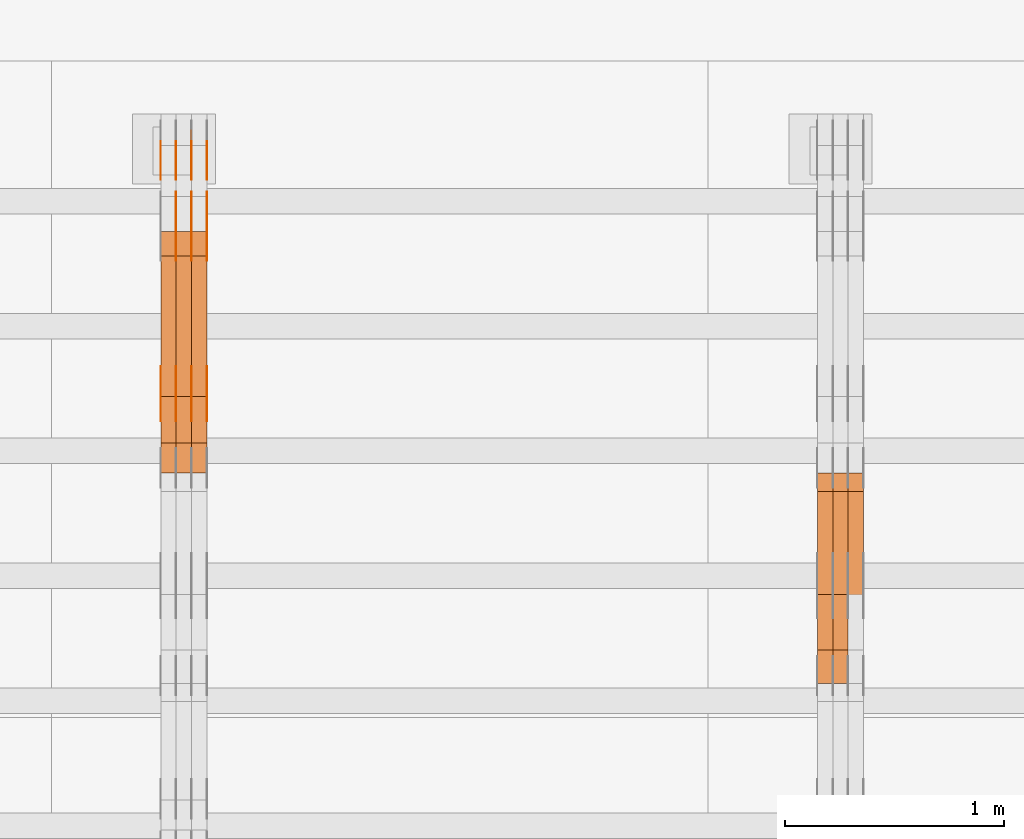
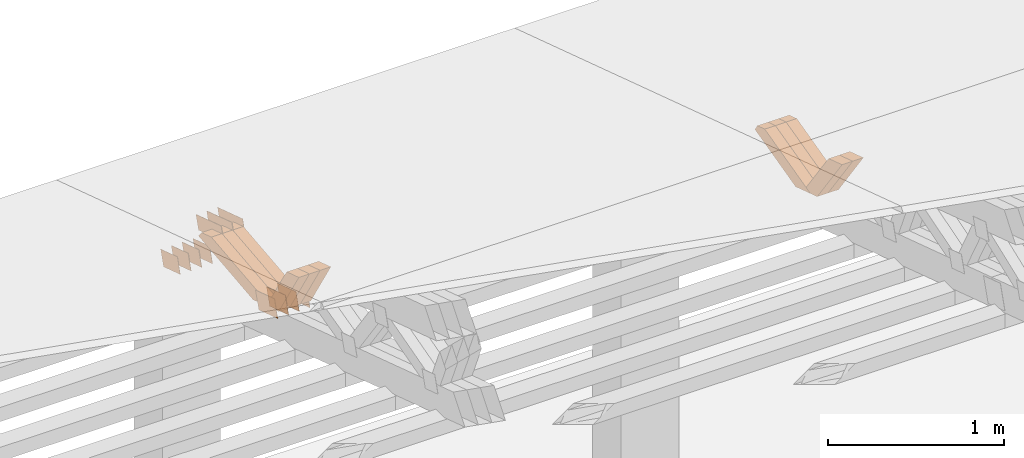
# One storey, part 207 of 385: 28 proxies.
"""IFC2X3 building model written with IfcOpenShell, lengths in millimetres."""

from ifc_helpers import new_model, entity, si_unit, converted_unit, derived_unit, direction, frame, origin, place, context, subcontext, project, spatial, polyline, outline, extrude, source, transform, mapped, material, type_object, type_shapes, element, save


model = new_model("IFC2X3")

# Units and contexts
model_context = context("Model", 3, precision=0.01, world=origin(), true_north=direction((6.12303176911189e-17, 1.0)))
body_context = subcontext(model_context, "Body", "Model", "MODEL_VIEW")
ifc_project = project(units=[si_unit("LENGTHUNIT", "METRE", prefix="MILLI"), si_unit("AREAUNIT", "SQUARE_METRE"), si_unit("VOLUMEUNIT", "CUBIC_METRE"), converted_unit("PLANEANGLEUNIT", "DEGREE", entity("IfcRatioMeasure", 0.0174532925199433), si_unit("PLANEANGLEUNIT", "RADIAN"), dimensions=[0, 0, 0, 0, 0, 0, 0]), si_unit("MASSUNIT", "GRAM", prefix="KILO"), derived_unit("MASSDENSITYUNIT", [(si_unit("MASSUNIT", "GRAM", prefix="KILO"), 1), (si_unit("LENGTHUNIT", "METRE"), -3)]), si_unit("TIMEUNIT", "SECOND"), si_unit("FREQUENCYUNIT", "HERTZ"), si_unit("THERMODYNAMICTEMPERATUREUNIT", "DEGREE_CELSIUS"), derived_unit("THERMALTRANSMITTANCEUNIT", [(si_unit("MASSUNIT", "GRAM", prefix="KILO"), 1), (si_unit("THERMODYNAMICTEMPERATUREUNIT", "KELVIN"), -1), (si_unit("TIMEUNIT", "SECOND"), -3)]), derived_unit("VOLUMETRICFLOWRATEUNIT", [(si_unit("LENGTHUNIT", "METRE"), 3), (si_unit("TIMEUNIT", "SECOND"), -1)]), si_unit("ELECTRICCURRENTUNIT", "AMPERE"), si_unit("ELECTRICVOLTAGEUNIT", "VOLT"), si_unit("POWERUNIT", "WATT"), si_unit("FORCEUNIT", "NEWTON", prefix="KILO"), si_unit("ILLUMINANCEUNIT", "LUX"), si_unit("LUMINOUSFLUXUNIT", "LUMEN"), si_unit("LUMINOUSINTENSITYUNIT", "CANDELA"), derived_unit("USERDEFINED", [(si_unit("MASSUNIT", "GRAM", prefix="KILO"), -1), (si_unit("LENGTHUNIT", "METRE"), -2), (si_unit("TIMEUNIT", "SECOND"), 3), (si_unit("LUMINOUSFLUXUNIT", "LUMEN"), 1)]), derived_unit("LINEARVELOCITYUNIT", [(si_unit("LENGTHUNIT", "METRE"), 1), (si_unit("TIMEUNIT", "SECOND"), -1)]), si_unit("PRESSUREUNIT", "PASCAL"), derived_unit("USERDEFINED", [(si_unit("LENGTHUNIT", "METRE"), -2), (si_unit("MASSUNIT", "GRAM", prefix="KILO"), 1), (si_unit("TIMEUNIT", "SECOND"), -2)])], contexts=[model_context])

# Site, building, storey
site_placement = place(None, origin())
site = spatial("IfcSite", under=ifc_project, at=site_placement, CompositionType="ELEMENT")
building_placement = place(site_placement, origin())
building = spatial("IfcBuilding", under=site, at=building_placement, CompositionType="ELEMENT")
storey_placement = place(building_placement, origin())
storey = spatial("IfcBuildingStorey", under=building, at=storey_placement, Name="Default", CompositionType="ELEMENT", Elevation=0.0)

# Proxies
ifc_material_1 = material(Name="IfcSurfaceStyle #182776")
building_element_proxy_type_1 = type_object("IfcBuildingElementProxyType", Name="T1-W24 182774", PredefinedType="NOTDEFINED", material=ifc_material_1)
shared_shape_1 = source(origin(), body_context, "Body", "SweptSolid", [
    extrude(outline(polyline([(-215.642157779899, -47.4998772343114), (220.829928576248, -47.4998772343114), (202.182343865616, 6.34871490324596e-05), (137.545638852774, 47.4998454907369), (-344.915753514738, 47.4998454907369), (-215.642157779899, -47.4998772343114)])), frame((220.830079609702, 47.500154567531, 0.0), z_axis=(0.0, 0.0, 1.0), x_axis=(-1.0, 0.0, 0.0)), (0.0, 0.0, 1.0), 70.0),
])
type_shapes(building_element_proxy_type_1, [shared_shape_1])
proxy_1_placement = place(building_placement, frame((15315.0, 24227.7045444998, 781.019082122604), z_axis=(-1.0, 0.0, 0.0), x_axis=(0.0, -0.583381854128324, 0.812198012970851)))
element("IfcBuildingElementProxy", 1, at=proxy_1_placement, inside=storey, type_object=building_element_proxy_type_1, material=ifc_material_1, Name="T1-W24", context=body_context, shape_type="MappedRepresentation", body=[
    mapped(shared_shape_1, transform((0.0, 0.0, 0.0), scale=1.0)),
])
ifc_material_2 = material(Name="IfcSurfaceStyle #182710")
building_element_proxy_type_2 = type_object("IfcBuildingElementProxyType", Name="T1-W24 182708", PredefinedType="NOTDEFINED", material=ifc_material_2)
shared_shape_2 = source(origin(), body_context, "Body", "SweptSolid", [
    extrude(outline(polyline([(-215.642157779899, -47.4998772343114), (220.829928576248, -47.4998772343114), (202.182343865616, 6.34871490324596e-05), (137.545638852774, 47.4998454907369), (-344.915753514738, 47.4998454907369), (-215.642157779899, -47.4998772343114)])), frame((220.830079609702, 47.500154567531, 0.0), z_axis=(0.0, 0.0, 1.0), x_axis=(-1.0, 0.0, 0.0)), (0.0, 0.0, 1.0), 70.0),
])
type_shapes(building_element_proxy_type_2, [shared_shape_2])
proxy_2_placement = place(building_placement, frame((15245.0, 24227.7045444998, 781.019082122604), z_axis=(-1.0, 0.0, 0.0), x_axis=(0.0, -0.583381854128324, 0.812198012970851)))
element("IfcBuildingElementProxy", 2, at=proxy_2_placement, inside=storey, type_object=building_element_proxy_type_2, material=ifc_material_2, Name="T1-W24", context=body_context, shape_type="MappedRepresentation", body=[
    mapped(shared_shape_2, transform((0.0, 0.0, 0.0), scale=1.0)),
])
ifc_material_3 = material(Name="IfcSurfaceStyle #182446")
building_element_proxy_type_3 = type_object("IfcBuildingElementProxyType", Name="T1-W13 182444", PredefinedType="NOTDEFINED", material=ifc_material_3)
shared_shape_3 = source(origin(), body_context, "Body", "SweptSolid", [
    extrude(outline(polyline([(-384.339592151497, -47.5000055308246), (150.996422207105, -47.5000055308247), (226.265349299398, -4.29484466835994e-05), (240.878612116891, 47.500027005048), (-233.800791471897, 47.500027005048), (-384.339592151497, -47.5000055308246)])), frame((240.878612116891, 47.500027005048, 0.0), z_axis=(0.0, 0.0, 1.0), x_axis=(-1.0, 0.0, 0.0)), (0.0, 0.0, 1.0), 70.0),
])
type_shapes(building_element_proxy_type_3, [shared_shape_3])
proxy_3_placement = place(building_placement, frame((15385.0, 24884.765625, 885.749145507813), z_axis=(-1.0, 0.0, 0.0), x_axis=(0.0, -0.969210894563555, -0.246232089418326)))
element("IfcBuildingElementProxy", 3, at=proxy_3_placement, inside=storey, type_object=building_element_proxy_type_3, material=ifc_material_3, Name="T1-W13", context=body_context, shape_type="MappedRepresentation", body=[
    mapped(shared_shape_3, transform((0.0, 0.0, 0.0), scale=1.0)),
])
ifc_material_4 = material(Name="IfcSurfaceStyle #182380")
building_element_proxy_type_4 = type_object("IfcBuildingElementProxyType", Name="T1-W13 182378", PredefinedType="NOTDEFINED", material=ifc_material_4)
shared_shape_4 = source(origin(), body_context, "Body", "SweptSolid", [
    extrude(outline(polyline([(-384.339592151497, -47.5000055308246), (150.996422207105, -47.5000055308247), (226.265349299398, -4.29484466835994e-05), (240.878612116891, 47.500027005048), (-233.800791471897, 47.500027005048), (-384.339592151497, -47.5000055308246)])), frame((240.878612116891, 47.500027005048, 0.0), z_axis=(0.0, 0.0, 1.0), x_axis=(-1.0, 0.0, 0.0)), (0.0, 0.0, 1.0), 70.0),
])
type_shapes(building_element_proxy_type_4, [shared_shape_4])
proxy_4_placement = place(building_placement, frame((15315.0, 24884.765625, 885.749145507813), z_axis=(-1.0, 0.0, 0.0), x_axis=(0.0, -0.969210894563555, -0.246232089418326)))
element("IfcBuildingElementProxy", 4, at=proxy_4_placement, inside=storey, type_object=building_element_proxy_type_4, material=ifc_material_4, Name="T1-W13", context=body_context, shape_type="MappedRepresentation", body=[
    mapped(shared_shape_4, transform((0.0, 0.0, 0.0), scale=1.0)),
])
ifc_material_5 = material(Name="IfcSurfaceStyle #182314")
building_element_proxy_type_5 = type_object("IfcBuildingElementProxyType", Name="T1-W13 182312", PredefinedType="NOTDEFINED", material=ifc_material_5)
shared_shape_5 = source(origin(), body_context, "Body", "SweptSolid", [
    extrude(outline(polyline([(-384.339592151497, -47.5000055308246), (150.996422207105, -47.5000055308247), (226.265349299398, -4.29484466835994e-05), (240.878612116891, 47.500027005048), (-233.800791471897, 47.500027005048), (-384.339592151497, -47.5000055308246)])), frame((240.878612116891, 47.500027005048, 0.0), z_axis=(0.0, 0.0, 1.0), x_axis=(-1.0, 0.0, 0.0)), (0.0, 0.0, 1.0), 70.0),
])
type_shapes(building_element_proxy_type_5, [shared_shape_5])
proxy_5_placement = place(building_placement, frame((15245.0, 24884.765625, 885.749145507813), z_axis=(-1.0, 0.0, 0.0), x_axis=(0.0, -0.969210894563555, -0.246232089418326)))
element("IfcBuildingElementProxy", 5, at=proxy_5_placement, inside=storey, type_object=building_element_proxy_type_5, material=ifc_material_5, Name="T1-W13", context=body_context, shape_type="MappedRepresentation", body=[
    mapped(shared_shape_5, transform((0.0, 0.0, 0.0), scale=1.0)),
])
ifc_material_6 = material(Name="IfcSurfaceStyle #171630")
building_element_proxy_type_6 = type_object("IfcBuildingElementProxyType", PredefinedType="NOTDEFINED", material=ifc_material_6)
shared_shape_6 = source(origin(), body_context, "Body", "SweptSolid", [
    extrude(outline(polyline([(-100.000024997547, -54.0000105875654), (100.000088940899, -54.0000105875654), (99.9999100805868, 54.0000105875654), (-99.9999740239394, 54.0000105875654), (-100.000024997547, -54.0000105875654)])), frame((100.000088940899, 54.0000474633838, 0.0), z_axis=(0.0, 0.0, 1.0), x_axis=(-1.0, 0.0, 0.0)), (0.0, 0.0, 1.0), 1.3),
])
type_shapes(building_element_proxy_type_6, [shared_shape_6])
proxy_6_placement = place(building_placement, frame((12386.3, 26390.6212638563, 73.3227520411355), z_axis=(-1.0, 0.0, 0.0), x_axis=(0.0, -0.951056516295124, 0.309016994375039)))
element("IfcBuildingElementProxy", 6, at=proxy_6_placement, inside=storey, type_object=building_element_proxy_type_6, material=ifc_material_6, context=body_context, shape_type="MappedRepresentation", body=[
    mapped(shared_shape_6, transform((0.0, 0.0, 0.0), scale=1.0)),
])
ifc_material_7 = material(Name="IfcSurfaceStyle #171573")
building_element_proxy_type_7 = type_object("IfcBuildingElementProxyType", PredefinedType="NOTDEFINED", material=ifc_material_7)
shared_shape_7 = source(origin(), body_context, "Body", "SweptSolid", [
    extrude(outline(polyline([(-100.000024997547, -54.0000105875654), (100.000088940899, -54.0000105875654), (99.9999100805868, 54.0000105875654), (-99.9999740239394, 54.0000105875654), (-100.000024997547, -54.0000105875654)])), frame((100.000088940899, 54.0000474633838, 0.0), z_axis=(0.0, 0.0, 1.0), x_axis=(-1.0, 0.0, 0.0)), (0.0, 0.0, 1.0), 1.3),
])
type_shapes(building_element_proxy_type_7, [shared_shape_7])
proxy_7_placement = place(building_placement, frame((12315.0, 26390.6212638563, 73.3227520411355), z_axis=(-1.0, 0.0, 0.0), x_axis=(0.0, -0.951056516295124, 0.309016994375039)))
element("IfcBuildingElementProxy", 7, at=proxy_7_placement, inside=storey, type_object=building_element_proxy_type_7, material=ifc_material_7, context=body_context, shape_type="MappedRepresentation", body=[
    mapped(shared_shape_7, transform((0.0, 0.0, 0.0), scale=1.0)),
])
ifc_material_8 = material(Name="IfcSurfaceStyle #171516")
building_element_proxy_type_8 = type_object("IfcBuildingElementProxyType", PredefinedType="NOTDEFINED", material=ifc_material_8)
shared_shape_8 = source(origin(), body_context, "Body", "SweptSolid", [
    extrude(outline(polyline([(-100.000024997547, -54.0000105875654), (100.000088940899, -54.0000105875654), (99.9999100805868, 54.0000105875654), (-99.9999740239394, 54.0000105875654), (-100.000024997547, -54.0000105875654)])), frame((100.000088940899, 54.0000474633838, 0.0), z_axis=(0.0, 0.0, 1.0), x_axis=(-1.0, 0.0, 0.0)), (0.0, 0.0, 1.0), 1.3),
])
type_shapes(building_element_proxy_type_8, [shared_shape_8])
proxy_8_placement = place(building_placement, frame((12316.3, 26390.6212638563, 73.3227520411355), z_axis=(-1.0, 0.0, 0.0), x_axis=(0.0, -0.951056516295124, 0.309016994375039)))
element("IfcBuildingElementProxy", 8, at=proxy_8_placement, inside=storey, type_object=building_element_proxy_type_8, material=ifc_material_8, context=body_context, shape_type="MappedRepresentation", body=[
    mapped(shared_shape_8, transform((0.0, 0.0, 0.0), scale=1.0)),
])
ifc_material_9 = material(Name="IfcSurfaceStyle #171459")
building_element_proxy_type_9 = type_object("IfcBuildingElementProxyType", PredefinedType="NOTDEFINED", material=ifc_material_9)
shared_shape_9 = source(origin(), body_context, "Body", "SweptSolid", [
    extrude(outline(polyline([(-100.000024997547, -54.0000105875654), (100.000088940899, -54.0000105875654), (99.9999100805868, 54.0000105875654), (-99.9999740239394, 54.0000105875654), (-100.000024997547, -54.0000105875654)])), frame((100.000088940899, 54.0000474633838, 0.0), z_axis=(0.0, 0.0, 1.0), x_axis=(-1.0, 0.0, 0.0)), (0.0, 0.0, 1.0), 1.29999999999998),
])
type_shapes(building_element_proxy_type_9, [shared_shape_9])
proxy_9_placement = place(building_placement, frame((12245.0, 26390.6212638563, 73.3227520411355), z_axis=(-1.0, 0.0, 0.0), x_axis=(0.0, -0.951056516295124, 0.309016994375039)))
element("IfcBuildingElementProxy", 9, at=proxy_9_placement, inside=storey, type_object=building_element_proxy_type_9, material=ifc_material_9, context=body_context, shape_type="MappedRepresentation", body=[
    mapped(shared_shape_9, transform((0.0, 0.0, 0.0), scale=1.0)),
])
ifc_material_10 = material(Name="IfcSurfaceStyle #171402")
building_element_proxy_type_10 = type_object("IfcBuildingElementProxyType", PredefinedType="NOTDEFINED", material=ifc_material_10)
shared_shape_10 = source(origin(), body_context, "Body", "SweptSolid", [
    extrude(outline(polyline([(-100.000024997547, -54.0000105875654), (100.000088940899, -54.0000105875654), (99.9999100805868, 54.0000105875654), (-99.9999740239394, 54.0000105875654), (-100.000024997547, -54.0000105875654)])), frame((100.000088940899, 54.0000474633838, 0.0), z_axis=(0.0, 0.0, 1.0), x_axis=(-1.0, 0.0, 0.0)), (0.0, 0.0, 1.0), 1.29999999999998),
])
type_shapes(building_element_proxy_type_10, [shared_shape_10])
proxy_10_placement = place(building_placement, frame((12246.3, 26390.6212638563, 73.3227520411355), z_axis=(-1.0, 0.0, 0.0), x_axis=(0.0, -0.951056516295124, 0.309016994375039)))
element("IfcBuildingElementProxy", 10, at=proxy_10_placement, inside=storey, type_object=building_element_proxy_type_10, material=ifc_material_10, context=body_context, shape_type="MappedRepresentation", body=[
    mapped(shared_shape_10, transform((0.0, 0.0, 0.0), scale=1.0)),
])
ifc_material_11 = material(Name="IfcSurfaceStyle #171345")
building_element_proxy_type_11 = type_object("IfcBuildingElementProxyType", PredefinedType="NOTDEFINED", material=ifc_material_11)
shared_shape_11 = source(origin(), body_context, "Body", "SweptSolid", [
    extrude(outline(polyline([(-100.000024997547, -54.0000105875654), (100.000088940899, -54.0000105875654), (99.9999100805868, 54.0000105875654), (-99.9999740239394, 54.0000105875654), (-100.000024997547, -54.0000105875654)])), frame((100.000088940899, 54.0000474633838, 0.0), z_axis=(0.0, 0.0, 1.0), x_axis=(-1.0, 0.0, 0.0)), (0.0, 0.0, 1.0), 1.29999999999999),
])
type_shapes(building_element_proxy_type_11, [shared_shape_11])
proxy_11_placement = place(building_placement, frame((12175.0, 26390.6212638563, 73.3227520411355), z_axis=(-1.0, 0.0, 0.0), x_axis=(0.0, -0.951056516295124, 0.309016994375039)))
element("IfcBuildingElementProxy", 11, at=proxy_11_placement, inside=storey, type_object=building_element_proxy_type_11, material=ifc_material_11, context=body_context, shape_type="MappedRepresentation", body=[
    mapped(shared_shape_11, transform((0.0, 0.0, 0.0), scale=1.0)),
])
ifc_material_12 = material(Name="IfcSurfaceStyle #159660")
building_element_proxy_type_12 = type_object("IfcBuildingElementProxyType", PredefinedType="NOTDEFINED", material=ifc_material_12)
shared_shape_12 = source(origin(), body_context, "Body", "SweptSolid", [
    extrude(outline(polyline([(-112.50003853564, -60.0000121429077), (112.50002982902, -60.0000121429077), (112.500043250865, 60.0000121429077), (-112.500034544245, 60.0000121429077), (-112.50003853564, -60.0000121429077)])), frame((112.500056021398, 60.0000121429077, 0.0), z_axis=(0.0, 0.0, 1.0), x_axis=(-1.0, 0.0, 0.0)), (0.0, 0.0, 1.0), 1.3),
])
type_shapes(building_element_proxy_type_12, [shared_shape_12])
proxy_12_placement = place(building_placement, frame((12386.3, 25310.2182710494, 430.675738123044), z_axis=(-1.0, 0.0, 0.0), x_axis=(0.0, -0.951056516295124, 0.309016994375039)))
element("IfcBuildingElementProxy", 12, at=proxy_12_placement, inside=storey, type_object=building_element_proxy_type_12, material=ifc_material_12, context=body_context, shape_type="MappedRepresentation", body=[
    mapped(shared_shape_12, transform((0.0, 0.0, 0.0), scale=1.0)),
])
ifc_material_13 = material(Name="IfcSurfaceStyle #159603")
building_element_proxy_type_13 = type_object("IfcBuildingElementProxyType", PredefinedType="NOTDEFINED", material=ifc_material_13)
shared_shape_13 = source(origin(), body_context, "Body", "SweptSolid", [
    extrude(outline(polyline([(-112.50003853564, -60.0000121429077), (112.50002982902, -60.0000121429077), (112.500043250865, 60.0000121429077), (-112.500034544245, 60.0000121429077), (-112.50003853564, -60.0000121429077)])), frame((112.500056021398, 60.0000121429077, 0.0), z_axis=(0.0, 0.0, 1.0), x_axis=(-1.0, 0.0, 0.0)), (0.0, 0.0, 1.0), 1.3),
])
type_shapes(building_element_proxy_type_13, [shared_shape_13])
proxy_13_placement = place(building_placement, frame((12315.0, 25310.2182710494, 430.675738123044), z_axis=(-1.0, 0.0, 0.0), x_axis=(0.0, -0.951056516295124, 0.309016994375039)))
element("IfcBuildingElementProxy", 13, at=proxy_13_placement, inside=storey, type_object=building_element_proxy_type_13, material=ifc_material_13, context=body_context, shape_type="MappedRepresentation", body=[
    mapped(shared_shape_13, transform((0.0, 0.0, 0.0), scale=1.0)),
])
ifc_material_14 = material(Name="IfcSurfaceStyle #159546")
building_element_proxy_type_14 = type_object("IfcBuildingElementProxyType", PredefinedType="NOTDEFINED", material=ifc_material_14)
shared_shape_14 = source(origin(), body_context, "Body", "SweptSolid", [
    extrude(outline(polyline([(-112.50003853564, -60.0000121429077), (112.50002982902, -60.0000121429077), (112.500043250865, 60.0000121429077), (-112.500034544245, 60.0000121429077), (-112.50003853564, -60.0000121429077)])), frame((112.500056021398, 60.0000121429077, 0.0), z_axis=(0.0, 0.0, 1.0), x_axis=(-1.0, 0.0, 0.0)), (0.0, 0.0, 1.0), 1.3),
])
type_shapes(building_element_proxy_type_14, [shared_shape_14])
proxy_14_placement = place(building_placement, frame((12316.3, 25310.2182710494, 430.675738123044), z_axis=(-1.0, 0.0, 0.0), x_axis=(0.0, -0.951056516295124, 0.309016994375039)))
element("IfcBuildingElementProxy", 14, at=proxy_14_placement, inside=storey, type_object=building_element_proxy_type_14, material=ifc_material_14, context=body_context, shape_type="MappedRepresentation", body=[
    mapped(shared_shape_14, transform((0.0, 0.0, 0.0), scale=1.0)),
])
ifc_material_15 = material(Name="IfcSurfaceStyle #159489")
building_element_proxy_type_15 = type_object("IfcBuildingElementProxyType", PredefinedType="NOTDEFINED", material=ifc_material_15)
shared_shape_15 = source(origin(), body_context, "Body", "SweptSolid", [
    extrude(outline(polyline([(-112.50003853564, -60.0000121429077), (112.50002982902, -60.0000121429077), (112.500043250865, 60.0000121429077), (-112.500034544245, 60.0000121429077), (-112.50003853564, -60.0000121429077)])), frame((112.500056021398, 60.0000121429077, 0.0), z_axis=(0.0, 0.0, 1.0), x_axis=(-1.0, 0.0, 0.0)), (0.0, 0.0, 1.0), 1.29999999999998),
])
type_shapes(building_element_proxy_type_15, [shared_shape_15])
proxy_15_placement = place(building_placement, frame((12245.0, 25310.2182710494, 430.675738123044), z_axis=(-1.0, 0.0, 0.0), x_axis=(0.0, -0.951056516295124, 0.309016994375039)))
element("IfcBuildingElementProxy", 15, at=proxy_15_placement, inside=storey, type_object=building_element_proxy_type_15, material=ifc_material_15, context=body_context, shape_type="MappedRepresentation", body=[
    mapped(shared_shape_15, transform((0.0, 0.0, 0.0), scale=1.0)),
])
ifc_material_16 = material(Name="IfcSurfaceStyle #159432")
building_element_proxy_type_16 = type_object("IfcBuildingElementProxyType", PredefinedType="NOTDEFINED", material=ifc_material_16)
shared_shape_16 = source(origin(), body_context, "Body", "SweptSolid", [
    extrude(outline(polyline([(-112.50003853564, -60.0000121429077), (112.50002982902, -60.0000121429077), (112.500043250865, 60.0000121429077), (-112.500034544245, 60.0000121429077), (-112.50003853564, -60.0000121429077)])), frame((112.500056021398, 60.0000121429077, 0.0), z_axis=(0.0, 0.0, 1.0), x_axis=(-1.0, 0.0, 0.0)), (0.0, 0.0, 1.0), 1.29999999999998),
])
type_shapes(building_element_proxy_type_16, [shared_shape_16])
proxy_16_placement = place(building_placement, frame((12246.3, 25310.2182710494, 430.675738123044), z_axis=(-1.0, 0.0, 0.0), x_axis=(0.0, -0.951056516295124, 0.309016994375039)))
element("IfcBuildingElementProxy", 16, at=proxy_16_placement, inside=storey, type_object=building_element_proxy_type_16, material=ifc_material_16, context=body_context, shape_type="MappedRepresentation", body=[
    mapped(shared_shape_16, transform((0.0, 0.0, 0.0), scale=1.0)),
])
ifc_material_17 = material(Name="IfcSurfaceStyle #159375")
building_element_proxy_type_17 = type_object("IfcBuildingElementProxyType", PredefinedType="NOTDEFINED", material=ifc_material_17)
shared_shape_17 = source(origin(), body_context, "Body", "SweptSolid", [
    extrude(outline(polyline([(-112.50003853564, -60.0000121429077), (112.50002982902, -60.0000121429077), (112.500043250865, 60.0000121429077), (-112.500034544245, 60.0000121429077), (-112.50003853564, -60.0000121429077)])), frame((112.500056021398, 60.0000121429077, 0.0), z_axis=(0.0, 0.0, 1.0), x_axis=(-1.0, 0.0, 0.0)), (0.0, 0.0, 1.0), 1.29999999999999),
])
type_shapes(building_element_proxy_type_17, [shared_shape_17])
proxy_17_placement = place(building_placement, frame((12175.0, 25310.2182710494, 430.675738123044), z_axis=(-1.0, 0.0, 0.0), x_axis=(0.0, -0.951056516295124, 0.309016994375039)))
element("IfcBuildingElementProxy", 17, at=proxy_17_placement, inside=storey, type_object=building_element_proxy_type_17, material=ifc_material_17, context=body_context, shape_type="MappedRepresentation", body=[
    mapped(shared_shape_17, transform((0.0, 0.0, 0.0), scale=1.0)),
])
ifc_material_18 = material(Name="IfcSurfaceStyle #158976")
building_element_proxy_type_18 = type_object("IfcBuildingElementProxyType", PredefinedType="NOTDEFINED", material=ifc_material_18)
shared_shape_18 = source(origin(), body_context, "Body", "SweptSolid", [
    extrude(outline(polyline([(-149.999901061401, -48.0000057587028), (150.000035297123, -48.0000057587028), (149.999910491851, 48.0000057587028), (-150.000044727574, 48.0000057587028), (-149.999901061401, -48.0000057587028)])), frame((150.000035297123, 48.0000632585775, 0.0), z_axis=(0.0, 0.0, 1.0), x_axis=(-1.0, 0.0, 0.0)), (0.0, 0.0, 1.0), 1.29999999999999),
])
type_shapes(building_element_proxy_type_18, [shared_shape_18])
proxy_18_placement = place(building_placement, frame((12386.3, 26115.0176968219, 469.58296924555), z_axis=(-1.0, 0.0, 0.0), x_axis=(0.0, -0.951056516295154, 0.309016994374948)))
element("IfcBuildingElementProxy", 18, at=proxy_18_placement, inside=storey, type_object=building_element_proxy_type_18, material=ifc_material_18, context=body_context, shape_type="MappedRepresentation", body=[
    mapped(shared_shape_18, transform((0.0, 0.0, 0.0), scale=1.0)),
])
ifc_material_19 = material(Name="IfcSurfaceStyle #158919")
building_element_proxy_type_19 = type_object("IfcBuildingElementProxyType", PredefinedType="NOTDEFINED", material=ifc_material_19)
shared_shape_19 = source(origin(), body_context, "Body", "SweptSolid", [
    extrude(outline(polyline([(-149.999901061401, -48.0000057587028), (150.000035297123, -48.0000057587028), (149.999910491851, 48.0000057587028), (-150.000044727574, 48.0000057587028), (-149.999901061401, -48.0000057587028)])), frame((150.000035297123, 48.0000632585775, 0.0), z_axis=(0.0, 0.0, 1.0), x_axis=(-1.0, 0.0, 0.0)), (0.0, 0.0, 1.0), 1.29999999999999),
])
type_shapes(building_element_proxy_type_19, [shared_shape_19])
proxy_19_placement = place(building_placement, frame((12315.0, 26115.0176968219, 469.58296924555), z_axis=(-1.0, 0.0, 0.0), x_axis=(0.0, -0.951056516295154, 0.309016994374948)))
element("IfcBuildingElementProxy", 19, at=proxy_19_placement, inside=storey, type_object=building_element_proxy_type_19, material=ifc_material_19, context=body_context, shape_type="MappedRepresentation", body=[
    mapped(shared_shape_19, transform((0.0, 0.0, 0.0), scale=1.0)),
])
ifc_material_20 = material(Name="IfcSurfaceStyle #158862")
building_element_proxy_type_20 = type_object("IfcBuildingElementProxyType", PredefinedType="NOTDEFINED", material=ifc_material_20)
shared_shape_20 = source(origin(), body_context, "Body", "SweptSolid", [
    extrude(outline(polyline([(-149.999901061401, -48.0000057587028), (150.000035297123, -48.0000057587028), (149.999910491851, 48.0000057587028), (-150.000044727574, 48.0000057587028), (-149.999901061401, -48.0000057587028)])), frame((150.000035297123, 48.0000632585775, 0.0), z_axis=(0.0, 0.0, 1.0), x_axis=(-1.0, 0.0, 0.0)), (0.0, 0.0, 1.0), 1.29999999999999),
])
type_shapes(building_element_proxy_type_20, [shared_shape_20])
proxy_20_placement = place(building_placement, frame((12316.3, 26115.0176968219, 469.58296924555), z_axis=(-1.0, 0.0, 0.0), x_axis=(0.0, -0.951056516295154, 0.309016994374948)))
element("IfcBuildingElementProxy", 20, at=proxy_20_placement, inside=storey, type_object=building_element_proxy_type_20, material=ifc_material_20, context=body_context, shape_type="MappedRepresentation", body=[
    mapped(shared_shape_20, transform((0.0, 0.0, 0.0), scale=1.0)),
])
ifc_material_21 = material(Name="IfcSurfaceStyle #158805")
building_element_proxy_type_21 = type_object("IfcBuildingElementProxyType", PredefinedType="NOTDEFINED", material=ifc_material_21)
shared_shape_21 = source(origin(), body_context, "Body", "SweptSolid", [
    extrude(outline(polyline([(-149.999901061401, -48.0000057587028), (150.000035297123, -48.0000057587028), (149.999910491851, 48.0000057587028), (-150.000044727574, 48.0000057587028), (-149.999901061401, -48.0000057587028)])), frame((150.000035297123, 48.0000632585775, 0.0), z_axis=(0.0, 0.0, 1.0), x_axis=(-1.0, 0.0, 0.0)), (0.0, 0.0, 1.0), 1.29999999999998),
])
type_shapes(building_element_proxy_type_21, [shared_shape_21])
proxy_21_placement = place(building_placement, frame((12245.0, 26115.0176968219, 469.58296924555), z_axis=(-1.0, 0.0, 0.0), x_axis=(0.0, -0.951056516295154, 0.309016994374948)))
element("IfcBuildingElementProxy", 21, at=proxy_21_placement, inside=storey, type_object=building_element_proxy_type_21, material=ifc_material_21, context=body_context, shape_type="MappedRepresentation", body=[
    mapped(shared_shape_21, transform((0.0, 0.0, 0.0), scale=1.0)),
])
ifc_material_22 = material(Name="IfcSurfaceStyle #158748")
building_element_proxy_type_22 = type_object("IfcBuildingElementProxyType", PredefinedType="NOTDEFINED", material=ifc_material_22)
shared_shape_22 = source(origin(), body_context, "Body", "SweptSolid", [
    extrude(outline(polyline([(-149.999901061401, -48.0000057587028), (150.000035297123, -48.0000057587028), (149.999910491851, 48.0000057587028), (-150.000044727574, 48.0000057587028), (-149.999901061401, -48.0000057587028)])), frame((150.000035297123, 48.0000632585775, 0.0), z_axis=(0.0, 0.0, 1.0), x_axis=(-1.0, 0.0, 0.0)), (0.0, 0.0, 1.0), 1.29999999999998),
])
type_shapes(building_element_proxy_type_22, [shared_shape_22])
proxy_22_placement = place(building_placement, frame((12246.3, 26115.0176968219, 469.58296924555), z_axis=(-1.0, 0.0, 0.0), x_axis=(0.0, -0.951056516295154, 0.309016994374948)))
element("IfcBuildingElementProxy", 22, at=proxy_22_placement, inside=storey, type_object=building_element_proxy_type_22, material=ifc_material_22, context=body_context, shape_type="MappedRepresentation", body=[
    mapped(shared_shape_22, transform((0.0, 0.0, 0.0), scale=1.0)),
])
ifc_material_23 = material(Name="IfcSurfaceStyle #147618")
building_element_proxy_type_23 = type_object("IfcBuildingElementProxyType", Name="T1-W31 147616", PredefinedType="NOTDEFINED", material=ifc_material_23)
shared_shape_23 = source(origin(), body_context, "Body", "SweptSolid", [
    extrude(outline(polyline([(-201.245318299844, -47.5000121670808), (204.413774229459, -47.5000121670808), (182.034306640891, 5.35692244583164e-05), (126.70380769348, 47.4999853824686), (-311.906570263987, 47.4999853824686), (-201.245318299844, -47.5000121670808)])), frame((204.413774229459, 47.5002684334588, 0.0), z_axis=(0.0, 0.0, 1.0), x_axis=(-1.0, 0.0, 0.0)), (0.0, 0.0, 1.0), 70.0),
])
type_shapes(building_element_proxy_type_23, [shared_shape_23])
proxy_23_placement = place(building_placement, frame((12385.0, 25127.5652647985, 487.27008059185), z_axis=(-1.0, 0.0, 0.0), x_axis=(0.0, -0.520333970303023, 0.853962855953755)))
element("IfcBuildingElementProxy", 23, at=proxy_23_placement, inside=storey, type_object=building_element_proxy_type_23, material=ifc_material_23, Name="T1-W31", context=body_context, shape_type="MappedRepresentation", body=[
    mapped(shared_shape_23, transform((0.0, 0.0, 0.0), scale=1.0)),
])
ifc_material_24 = material(Name="IfcSurfaceStyle #147552")
building_element_proxy_type_24 = type_object("IfcBuildingElementProxyType", Name="T1-W31 147550", PredefinedType="NOTDEFINED", material=ifc_material_24)
shared_shape_24 = source(origin(), body_context, "Body", "SweptSolid", [
    extrude(outline(polyline([(-201.245318299844, -47.5000121670808), (204.413774229459, -47.5000121670808), (182.034306640891, 5.35692244583164e-05), (126.70380769348, 47.4999853824686), (-311.906570263987, 47.4999853824686), (-201.245318299844, -47.5000121670808)])), frame((204.413774229459, 47.5002684334588, 0.0), z_axis=(0.0, 0.0, 1.0), x_axis=(-1.0, 0.0, 0.0)), (0.0, 0.0, 1.0), 70.0),
])
type_shapes(building_element_proxy_type_24, [shared_shape_24])
proxy_24_placement = place(building_placement, frame((12315.0, 25127.5652647985, 487.27008059185), z_axis=(-1.0, 0.0, 0.0), x_axis=(0.0, -0.520333970303023, 0.853962855953755)))
element("IfcBuildingElementProxy", 24, at=proxy_24_placement, inside=storey, type_object=building_element_proxy_type_24, material=ifc_material_24, Name="T1-W31", context=body_context, shape_type="MappedRepresentation", body=[
    mapped(shared_shape_24, transform((0.0, 0.0, 0.0), scale=1.0)),
])
ifc_material_25 = material(Name="IfcSurfaceStyle #147486")
building_element_proxy_type_25 = type_object("IfcBuildingElementProxyType", Name="T1-W31 147484", PredefinedType="NOTDEFINED", material=ifc_material_25)
shared_shape_25 = source(origin(), body_context, "Body", "SweptSolid", [
    extrude(outline(polyline([(-201.245318299844, -47.5000121670808), (204.413774229459, -47.5000121670808), (182.034306640891, 5.35692244583164e-05), (126.70380769348, 47.4999853824686), (-311.906570263987, 47.4999853824686), (-201.245318299844, -47.5000121670808)])), frame((204.413774229459, 47.5002684334588, 0.0), z_axis=(0.0, 0.0, 1.0), x_axis=(-1.0, 0.0, 0.0)), (0.0, 0.0, 1.0), 70.0),
])
type_shapes(building_element_proxy_type_25, [shared_shape_25])
proxy_25_placement = place(building_placement, frame((12245.0, 25127.5652647985, 487.27008059185), z_axis=(-1.0, 0.0, 0.0), x_axis=(0.0, -0.520333970303023, 0.853962855953755)))
element("IfcBuildingElementProxy", 25, at=proxy_25_placement, inside=storey, type_object=building_element_proxy_type_25, material=ifc_material_25, Name="T1-W31", context=body_context, shape_type="MappedRepresentation", body=[
    mapped(shared_shape_25, transform((0.0, 0.0, 0.0), scale=1.0)),
])
ifc_material_26 = material(Name="IfcSurfaceStyle #147222")
building_element_proxy_type_26 = type_object("IfcBuildingElementProxyType", Name="T1-W4 147220", PredefinedType="NOTDEFINED", material=ifc_material_26)
shared_shape_26 = source(origin(), body_context, "Body", "SweptSolid", [
    extrude(outline(polyline([(-510.077325435179, -47.4999981284922), (188.854793418912, -47.4999981284922), (294.906688207675, 1.67015383116809e-05), (324.289382923648, 47.499989777723), (-297.973539115057, 47.4999897777231), (-510.077325435179, -47.4999981284922)])), frame((324.289382923648, 47.5000278316275, 0.0), z_axis=(0.0, 0.0, 1.0), x_axis=(-1.0, 0.0, 0.0)), (0.0, 0.0, 1.0), 70.0),
])
type_shapes(building_element_proxy_type_26, [shared_shape_26])
proxy_26_placement = place(building_placement, frame((12385.0, 25996.2241251556, 525.69905884318), z_axis=(-1.0, 0.0, 0.0), x_axis=(0.0, -0.994287125203057, -0.106738524701444)))
element("IfcBuildingElementProxy", 26, at=proxy_26_placement, inside=storey, type_object=building_element_proxy_type_26, material=ifc_material_26, Name="T1-W4", context=body_context, shape_type="MappedRepresentation", body=[
    mapped(shared_shape_26, transform((0.0, 0.0, 0.0), scale=1.0)),
])
ifc_material_27 = material(Name="IfcSurfaceStyle #147156")
building_element_proxy_type_27 = type_object("IfcBuildingElementProxyType", Name="T1-W4 147154", PredefinedType="NOTDEFINED", material=ifc_material_27)
shared_shape_27 = source(origin(), body_context, "Body", "SweptSolid", [
    extrude(outline(polyline([(-510.077325435179, -47.4999981284922), (188.854793418912, -47.4999981284922), (294.906688207675, 1.67015383116809e-05), (324.289382923648, 47.499989777723), (-297.973539115057, 47.4999897777231), (-510.077325435179, -47.4999981284922)])), frame((324.289382923648, 47.5000278316275, 0.0), z_axis=(0.0, 0.0, 1.0), x_axis=(-1.0, 0.0, 0.0)), (0.0, 0.0, 1.0), 70.0),
])
type_shapes(building_element_proxy_type_27, [shared_shape_27])
proxy_27_placement = place(building_placement, frame((12315.0, 25996.2241251556, 525.69905884318), z_axis=(-1.0, 0.0, 0.0), x_axis=(0.0, -0.994287125203057, -0.106738524701444)))
element("IfcBuildingElementProxy", 27, at=proxy_27_placement, inside=storey, type_object=building_element_proxy_type_27, material=ifc_material_27, Name="T1-W4", context=body_context, shape_type="MappedRepresentation", body=[
    mapped(shared_shape_27, transform((0.0, 0.0, 0.0), scale=1.0)),
])
ifc_material_28 = material(Name="IfcSurfaceStyle #147090")
building_element_proxy_type_28 = type_object("IfcBuildingElementProxyType", Name="T1-W4 147088", PredefinedType="NOTDEFINED", material=ifc_material_28)
shared_shape_28 = source(origin(), body_context, "Body", "SweptSolid", [
    extrude(outline(polyline([(-510.077325435179, -47.4999981284922), (188.854793418912, -47.4999981284922), (294.906688207675, 1.67015383116809e-05), (324.289382923648, 47.499989777723), (-297.973539115057, 47.4999897777231), (-510.077325435179, -47.4999981284922)])), frame((324.289382923648, 47.5000278316275, 0.0), z_axis=(0.0, 0.0, 1.0), x_axis=(-1.0, 0.0, 0.0)), (0.0, 0.0, 1.0), 70.0),
])
type_shapes(building_element_proxy_type_28, [shared_shape_28])
proxy_28_placement = place(building_placement, frame((12245.0, 25996.2241251556, 525.69905884318), z_axis=(-1.0, 0.0, 0.0), x_axis=(0.0, -0.994287125203057, -0.106738524701444)))
element("IfcBuildingElementProxy", 28, at=proxy_28_placement, inside=storey, type_object=building_element_proxy_type_28, material=ifc_material_28, Name="T1-W4", context=body_context, shape_type="MappedRepresentation", body=[
    mapped(shared_shape_28, transform((0.0, 0.0, 0.0), scale=1.0)),
])

save(model, "model.ifc")
